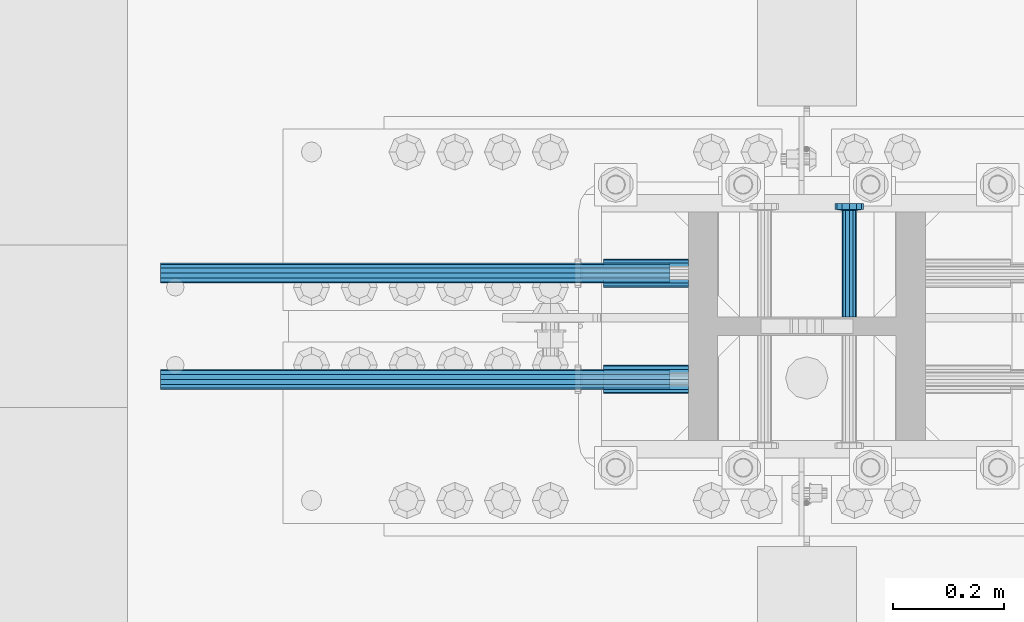
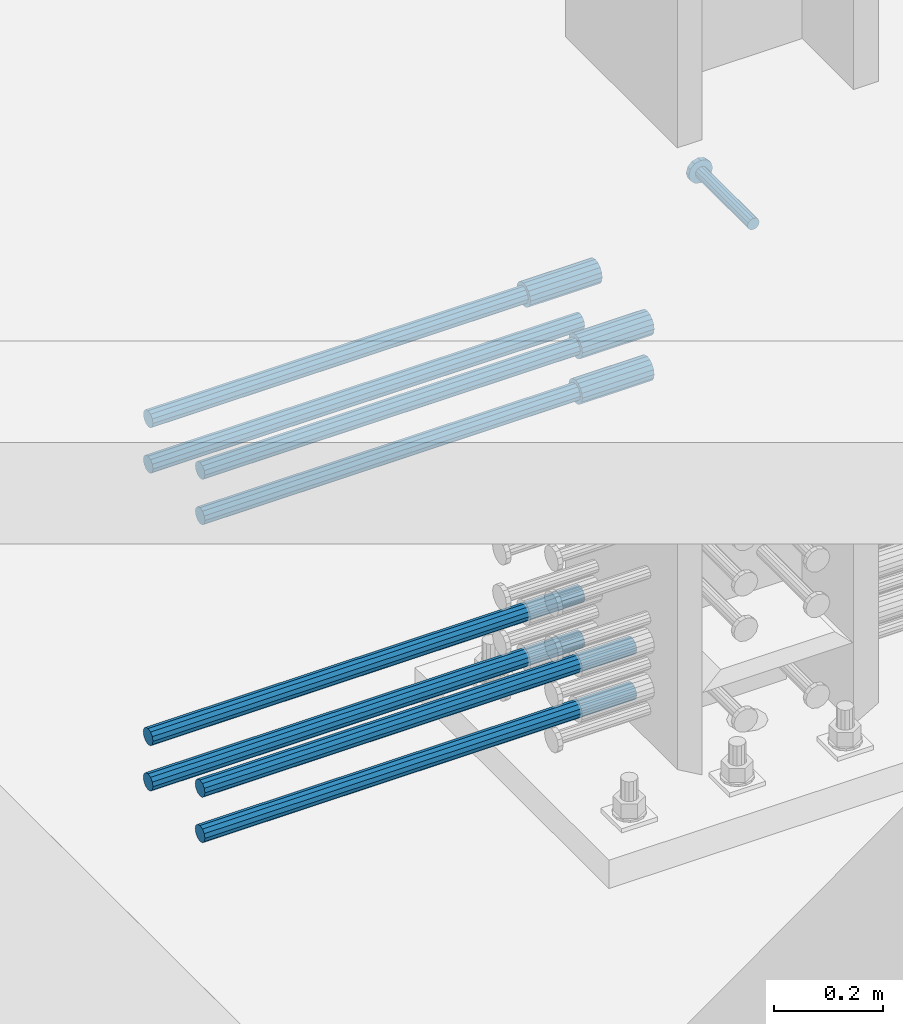
# One storey, part 1225 of 1763: 12 beams, 9 elements without a shape of their own.
"""IFC2X3 building model written with IfcOpenShell, lengths in millimetres."""

from ifc_helpers import new_model, si_unit, frame, origin_with_axes, place, context, subcontext, project, spatial, faceted_brep, material, type_object, element, aggregate, save


model = new_model("IFC2X3")

# Units and contexts
model_context = context("Model", 3, precision=1e-05, world=origin_with_axes())
body_context = subcontext(model_context, "Body", "Model", "MODEL_VIEW")
ifc_project = project(units=[si_unit("LENGTHUNIT", "METRE", prefix="MILLI"), si_unit("AREAUNIT", "SQUARE_METRE"), si_unit("VOLUMEUNIT", "CUBIC_METRE"), si_unit("MASSUNIT", "GRAM", prefix="KILO"), si_unit("TIMEUNIT", "SECOND"), si_unit("PLANEANGLEUNIT", "RADIAN"), si_unit("SOLIDANGLEUNIT", "STERADIAN"), si_unit("THERMODYNAMICTEMPERATUREUNIT", "DEGREE_CELSIUS"), si_unit("LUMINOUSINTENSITYUNIT", "LUMEN")], contexts=[model_context])

# Site, building, storey
site_placement = place(None, origin_with_axes())
site = spatial("IfcSite", under=ifc_project, at=site_placement, CompositionType="ELEMENT")
building_placement = place(site_placement, origin_with_axes())
building = spatial("IfcBuilding", under=site, at=building_placement, Name="Undefined", CompositionType="ELEMENT")
storey_placement = place(building_placement, origin_with_axes())
storey = spatial("IfcBuildingStorey", under=building, at=storey_placement, Name="Undefined", CompositionType="ELEMENT", Elevation=0.0)

# Assembly, beams
assembly_1_placement = place(storey_placement, origin_with_axes())
assembly_1 = element("IfcElementAssembly", 1, at=assembly_1_placement, inside=storey, Name="COLUMN", AssemblyPlace="NOTDEFINED", PredefinedType="RIGID_FRAME")
ifc_material_1 = material(Name="STEEL/A706-GR.80")
beam_type_1 = type_object("IfcBeamType", PredefinedType="NOTDEFINED")
beam_1_placement = place(assembly_1_placement, frame((-49615.1621920032, 361.950000000003, 4775.20000000009), z_axis=(0.0, 0.0, 1.0), x_axis=(-1.0, 0.0, 0.0)))
beam_1 = element("IfcBeam", 2, at=beam_1_placement, type_object=beam_type_1, material=ifc_material_1, Name="HALF COUPLER F", context=body_context, shape_type="Brep", body=[
    faceted_brep([(32.7659999999996, -8.95349999999962, -15.507916905568), (32.7659999999996, 0.0, -17.9070000000002), (32.7659999999996, 8.95349999999962, -15.507916905568), (32.7659999999996, 15.507916905568, -8.95350000000008), (32.7659999999996, 17.9069999999992, 0.0), (32.7659999999996, 15.507916905568, 8.95350000000008), (32.7659999999996, 8.95349999999962, 15.507916905568), (32.7659999999996, 0.0, 17.9070000000002), (32.7659999999996, -8.95349999999962, 15.507916905568), (32.7659999999996, -15.507916905568, 8.95350000000008), (32.7659999999996, -17.9069999999992, 0.0), (32.7659999999996, -15.507916905568, -8.95350000000008), (152.400103102711, -15.507916905568, 8.95350000000008), (152.400103102711, -8.95349999999962, 15.507916905568), (152.400103102711, -17.9069999999992, 0.0), (152.400103102711, -15.507916905568, -8.95350000000008), (152.400103102711, -8.95349999999962, -15.507916905568), (152.400103102711, 0.0, -17.9070000000002), (152.400103102711, 8.95349999999962, -15.507916905568), (152.400103102711, 15.507916905568, -8.95350000000008), (152.400103102711, 17.9069999999992, 0.0), (152.400103102711, 15.507916905568, 8.95350000000008), (152.400103102711, 8.95349999999962, 15.507916905568), (152.400103102711, 0.0, 17.9070000000002), (0.0, -23.466540125788, 9.72015918207308), (0.0, -17.9605122421381, 17.9605122421385), (0.0, -9.72015918207398, 23.4665401257867), (0.0, 0.0, 25.4000000000001), (0.0, 9.72015918207398, 23.4665401257867), (0.0, 17.9605122421381, 17.9605122421385), (0.0, 23.466540125788, 9.72015918207308), (0.0, 25.4000000000015, 0.0), (0.0, 23.466540125788, -9.72015918207308), (0.0, 17.9605122421381, -17.9605122421385), (0.0, 9.72015918207398, -23.4665401257867), (0.0, 0.0, -25.4000000000001), (0.0, -9.72015918207398, -23.4665401257867), (0.0, -17.9605122421381, -17.9605122421385), (0.0, -23.466540125788, -9.72015918207308), (0.0, -25.4000000000015, 0.0), (152.400103102711, -25.4000000000015, 0.0), (152.400103102711, -23.466540125788, 9.72015918207308), (152.400103102711, -17.9605122421381, 17.9605122421385), (152.400103102711, -9.72015918207398, 23.4665401257867), (152.400103102711, 0.0, 25.4000000000001), (152.400103102711, 9.72015918207398, 23.4665401257867), (152.400103102711, 17.9605122421381, 17.9605122421385), (152.400103102711, 23.466540125788, 9.72015918207308), (152.400103102711, 25.4000000000015, 0.0), (152.400103102711, 23.466540125788, -9.72015918207308), (152.400103102711, 17.9605122421381, -17.9605122421385), (152.400103102711, 9.72015918207398, -23.4665401257867), (152.400103102711, 0.0, -25.4000000000001), (152.400103102711, -9.72015918207398, -23.4665401257867), (152.400103102711, -17.9605122421381, -17.9605122421385), (152.400103102711, -23.466540125788, -9.72015918207308)], [[[0, 1, 2, 3, 4, 5, 6, 7, 8, 9, 10, 11]], [[12, 9, 8, 13]], [[14, 10, 9, 12]], [[15, 11, 10, 14]], [[16, 0, 11, 15]], [[17, 1, 0, 16]], [[18, 2, 1, 17]], [[19, 3, 2, 18]], [[20, 4, 3, 19]], [[21, 5, 4, 20]], [[22, 6, 5, 21]], [[23, 7, 6, 22]], [[13, 8, 7, 23]], [[24, 25, 26, 27, 28, 29, 30, 31, 32, 33, 34, 35, 36, 37, 38, 39]], [[24, 39, 40, 41]], [[25, 24, 41, 42]], [[26, 25, 42, 43]], [[27, 26, 43, 44]], [[28, 27, 44, 45]], [[29, 28, 45, 46]], [[30, 29, 46, 47]], [[31, 30, 47, 48]], [[32, 31, 48, 49]], [[33, 32, 49, 50]], [[34, 33, 50, 51]], [[35, 34, 51, 52]], [[36, 35, 52, 53]], [[37, 36, 53, 54]], [[38, 37, 54, 55]], [[39, 38, 55, 40]], [[54, 53, 52, 51, 50, 49, 48, 47, 46, 45, 44, 43, 42, 41, 40, 55], [21, 20, 19, 18, 17, 16, 15, 14, 12, 13, 23, 22]]]),
])
beam_2_placement = place(assembly_1_placement, frame((-49615.162260665, 552.449999999415, 4876.80000000009), z_axis=(0.0, 0.0, 1.0), x_axis=(-1.0, 0.0, 0.0)))
beam_2 = element("IfcBeam", 3, at=beam_2_placement, type_object=beam_type_1, material=ifc_material_1, Name="HALF COUPLER F", context=body_context, shape_type="Brep", body=[
    faceted_brep([(32.7659999999996, -8.95349999999962, -15.507916905568), (32.7659999999996, 0.0, -17.9070000000002), (32.7659999999996, 8.95349999999962, -15.507916905568), (32.7659999999996, 15.507916905568, -8.95350000000008), (32.7659999999996, 17.9069999999992, 0.0), (32.7659999999996, 15.507916905568, 8.95350000000008), (32.7659999999996, 8.95349999999962, 15.507916905568), (32.7659999999996, 0.0, 17.9070000000002), (32.7659999999996, -8.95349999999962, 15.507916905568), (32.7659999999996, -15.507916905568, 8.95350000000008), (32.7659999999996, -17.9069999999992, 0.0), (32.7659999999996, -15.507916905568, -8.95350000000008), (152.400103102711, -15.507916905568, 8.95350000000008), (152.400103102711, -8.95349999999962, 15.507916905568), (152.400103102711, -17.9069999999992, 0.0), (152.400103102711, -15.507916905568, -8.95350000000008), (152.400103102711, -8.95349999999962, -15.507916905568), (152.400103102711, 0.0, -17.9070000000002), (152.400103102711, 8.95349999999962, -15.507916905568), (152.400103102711, 15.507916905568, -8.95350000000008), (152.400103102711, 17.9069999999992, 0.0), (152.400103102711, 15.507916905568, 8.95350000000008), (152.400103102711, 8.95349999999962, 15.507916905568), (152.400103102711, 0.0, 17.9070000000002), (0.0, -23.466540125788, 9.72015918207308), (0.0, -17.9605122421381, 17.9605122421385), (0.0, -9.72015918207398, 23.4665401257867), (0.0, 0.0, 25.4000000000001), (0.0, 9.72015918207398, 23.4665401257867), (0.0, 17.9605122421381, 17.9605122421385), (0.0, 23.466540125788, 9.72015918207308), (0.0, 25.4000000000015, 0.0), (0.0, 23.466540125788, -9.72015918207308), (0.0, 17.9605122421381, -17.9605122421385), (0.0, 9.72015918207398, -23.4665401257867), (0.0, 0.0, -25.4000000000001), (0.0, -9.72015918207398, -23.4665401257867), (0.0, -17.9605122421381, -17.9605122421385), (0.0, -23.466540125788, -9.72015918207308), (0.0, -25.4000000000015, 0.0), (152.400103102711, -25.4000000000015, 0.0), (152.400103102711, -23.466540125788, 9.72015918207308), (152.400103102711, -17.9605122421381, 17.9605122421385), (152.400103102711, -9.72015918207398, 23.4665401257867), (152.400103102711, 0.0, 25.4000000000001), (152.400103102711, 9.72015918207398, 23.4665401257867), (152.400103102711, 17.9605122421381, 17.9605122421385), (152.400103102711, 23.466540125788, 9.72015918207308), (152.400103102711, 25.4000000000015, 0.0), (152.400103102711, 23.466540125788, -9.72015918207308), (152.400103102711, 17.9605122421381, -17.9605122421385), (152.400103102711, 9.72015918207398, -23.4665401257867), (152.400103102711, 0.0, -25.4000000000001), (152.400103102711, -9.72015918207398, -23.4665401257867), (152.400103102711, -17.9605122421381, -17.9605122421385), (152.400103102711, -23.466540125788, -9.72015918207308)], [[[0, 1, 2, 3, 4, 5, 6, 7, 8, 9, 10, 11]], [[12, 9, 8, 13]], [[14, 10, 9, 12]], [[15, 11, 10, 14]], [[16, 0, 11, 15]], [[17, 1, 0, 16]], [[18, 2, 1, 17]], [[19, 3, 2, 18]], [[20, 4, 3, 19]], [[21, 5, 4, 20]], [[22, 6, 5, 21]], [[23, 7, 6, 22]], [[13, 8, 7, 23]], [[24, 25, 26, 27, 28, 29, 30, 31, 32, 33, 34, 35, 36, 37, 38, 39]], [[24, 39, 40, 41]], [[25, 24, 41, 42]], [[26, 25, 42, 43]], [[27, 26, 43, 44]], [[28, 27, 44, 45]], [[29, 28, 45, 46]], [[30, 29, 46, 47]], [[31, 30, 47, 48]], [[32, 31, 48, 49]], [[33, 32, 49, 50]], [[34, 33, 50, 51]], [[35, 34, 51, 52]], [[36, 35, 52, 53]], [[37, 36, 53, 54]], [[38, 37, 54, 55]], [[39, 38, 55, 40]], [[54, 53, 52, 51, 50, 49, 48, 47, 46, 45, 44, 43, 42, 41, 40, 55], [21, 20, 19, 18, 17, 16, 15, 14, 12, 13, 23, 22]]]),
])
beam_3_placement = place(assembly_1_placement, frame((-49615.1621920032, 361.950000000003, 4876.80000000009), z_axis=(0.0, 0.0, 1.0), x_axis=(-1.0, 0.0, 0.0)))
beam_3 = element("IfcBeam", 4, at=beam_3_placement, type_object=beam_type_1, material=ifc_material_1, Name="HALF COUPLER F", context=body_context, shape_type="Brep", body=[
    faceted_brep([(32.7659999999996, -8.95349999999962, -15.507916905568), (32.7659999999996, 0.0, -17.9070000000002), (32.7659999999996, 8.95349999999962, -15.507916905568), (32.7659999999996, 15.507916905568, -8.95350000000008), (32.7659999999996, 17.9069999999992, 0.0), (32.7659999999996, 15.507916905568, 8.95350000000008), (32.7659999999996, 8.95349999999962, 15.507916905568), (32.7659999999996, 0.0, 17.9070000000002), (32.7659999999996, -8.95349999999962, 15.507916905568), (32.7659999999996, -15.507916905568, 8.95350000000008), (32.7659999999996, -17.9069999999992, 0.0), (32.7659999999996, -15.507916905568, -8.95350000000008), (152.400103102711, -15.507916905568, 8.95350000000008), (152.400103102711, -8.95349999999962, 15.507916905568), (152.400103102711, -17.9069999999992, 0.0), (152.400103102711, -15.507916905568, -8.95350000000008), (152.400103102711, -8.95349999999962, -15.507916905568), (152.400103102711, 0.0, -17.9070000000002), (152.400103102711, 8.95349999999962, -15.507916905568), (152.400103102711, 15.507916905568, -8.95350000000008), (152.400103102711, 17.9069999999992, 0.0), (152.400103102711, 15.507916905568, 8.95350000000008), (152.400103102711, 8.95349999999962, 15.507916905568), (152.400103102711, 0.0, 17.9070000000002), (0.0, -23.466540125788, 9.72015918207308), (0.0, -17.9605122421381, 17.9605122421385), (0.0, -9.72015918207398, 23.4665401257867), (0.0, 0.0, 25.4000000000001), (0.0, 9.72015918207398, 23.4665401257867), (0.0, 17.9605122421381, 17.9605122421385), (0.0, 23.466540125788, 9.72015918207308), (0.0, 25.4000000000015, 0.0), (0.0, 23.466540125788, -9.72015918207308), (0.0, 17.9605122421381, -17.9605122421385), (0.0, 9.72015918207398, -23.4665401257867), (0.0, 0.0, -25.4000000000001), (0.0, -9.72015918207398, -23.4665401257867), (0.0, -17.9605122421381, -17.9605122421385), (0.0, -23.466540125788, -9.72015918207308), (0.0, -25.4000000000015, 0.0), (152.400103102711, -25.4000000000015, 0.0), (152.400103102711, -23.466540125788, 9.72015918207308), (152.400103102711, -17.9605122421381, 17.9605122421385), (152.400103102711, -9.72015918207398, 23.4665401257867), (152.400103102711, 0.0, 25.4000000000001), (152.400103102711, 9.72015918207398, 23.4665401257867), (152.400103102711, 17.9605122421381, 17.9605122421385), (152.400103102711, 23.466540125788, 9.72015918207308), (152.400103102711, 25.4000000000015, 0.0), (152.400103102711, 23.466540125788, -9.72015918207308), (152.400103102711, 17.9605122421381, -17.9605122421385), (152.400103102711, 9.72015918207398, -23.4665401257867), (152.400103102711, 0.0, -25.4000000000001), (152.400103102711, -9.72015918207398, -23.4665401257867), (152.400103102711, -17.9605122421381, -17.9605122421385), (152.400103102711, -23.466540125788, -9.72015918207308)], [[[0, 1, 2, 3, 4, 5, 6, 7, 8, 9, 10, 11]], [[12, 9, 8, 13]], [[14, 10, 9, 12]], [[15, 11, 10, 14]], [[16, 0, 11, 15]], [[17, 1, 0, 16]], [[18, 2, 1, 17]], [[19, 3, 2, 18]], [[20, 4, 3, 19]], [[21, 5, 4, 20]], [[22, 6, 5, 21]], [[23, 7, 6, 22]], [[13, 8, 7, 23]], [[24, 25, 26, 27, 28, 29, 30, 31, 32, 33, 34, 35, 36, 37, 38, 39]], [[24, 39, 40, 41]], [[25, 24, 41, 42]], [[26, 25, 42, 43]], [[27, 26, 43, 44]], [[28, 27, 44, 45]], [[29, 28, 45, 46]], [[30, 29, 46, 47]], [[31, 30, 47, 48]], [[32, 31, 48, 49]], [[33, 32, 49, 50]], [[34, 33, 50, 51]], [[35, 34, 51, 52]], [[36, 35, 52, 53]], [[37, 36, 53, 54]], [[38, 37, 54, 55]], [[39, 38, 55, 40]], [[54, 53, 52, 51, 50, 49, 48, 47, 46, 45, 44, 43, 42, 41, 40, 55], [21, 20, 19, 18, 17, 16, 15, 14, 12, 13, 23, 22]]]),
])

# Assembly, beam
assembly_2_placement = place(storey_placement, origin_with_axes())
assembly_2 = element("IfcElementAssembly", 5, at=assembly_2_placement, inside=storey, Name="REBAR", AssemblyPlace="NOTDEFINED", PredefinedType="RIGID_FRAME")
beam_type_2 = type_object("IfcBeamType", Name="#11 REBAR", PredefinedType="NOTDEFINED")
beam_4_placement = place(assembly_2_placement, frame((-49647.9281232677, 361.949999997454, 4063.99999999999), z_axis=(0.0, 0.0, -1.0), x_axis=(-1.0, 0.0, 0.0)))
beam_4 = element("IfcBeam", 6, at=beam_4_placement, type_object=beam_type_2, material=ifc_material_1, Name="REBAR", ObjectType="#11 REBAR", context=body_context, shape_type="Brep", body=[
    faceted_brep([(0.0, -17.9069999999992, 0.0), (0.0, -15.507916905568, -8.95349999999962), (914.400000001086, -15.507916905568, -8.95349999999962), (914.400000001086, -17.9069999999992, 0.0), (0.0, -8.95349999999962, -15.507916905568), (914.400000001086, -8.95349999999962, -15.507916905568), (0.0, 0.0, -17.9070000000002), (914.400000001086, 0.0, -17.9070000000002), (0.0, 8.95349999999962, -15.507916905568), (914.400000001086, 8.95349999999962, -15.507916905568), (0.0, 15.507916905568, -8.95349999999962), (914.400000001086, 15.507916905568, -8.95349999999962), (0.0, 17.9069999999992, 0.0), (914.400000001086, 17.9069999999992, 0.0), (0.0, 15.507916905568, 8.95349999999962), (914.400000001086, 15.507916905568, 8.95349999999962), (0.0, 8.95349999999962, 15.507916905568), (914.400000001086, 8.95349999999962, 15.507916905568), (0.0, 0.0, 17.9070000000002), (914.400000001086, 0.0, 17.9070000000002), (0.0, -8.95349999999962, 15.507916905568), (914.400000001086, -8.95349999999962, 15.507916905568), (0.0, -15.507916905568, 8.95349999999962), (914.400000001086, -15.507916905568, 8.95349999999962)], [[[0, 1, 2, 3]], [[1, 4, 5, 2]], [[4, 6, 7, 5]], [[6, 8, 9, 7]], [[8, 10, 11, 9]], [[10, 12, 13, 11]], [[12, 14, 15, 13]], [[14, 16, 17, 15]], [[16, 18, 19, 17]], [[18, 20, 21, 19]], [[20, 22, 23, 21]], [[22, 0, 3, 23]], [[5, 7, 9, 11, 13, 15, 17, 19, 21, 23, 3, 2]], [[22, 20, 18, 16, 14, 12, 10, 8, 6, 4, 1, 0]]]),
])
aggregate(assembly_2, [beam_4])

assembly_3_placement = place(storey_placement, origin_with_axes())
assembly_3 = element("IfcElementAssembly", 7, at=assembly_3_placement, inside=storey, Name="REBAR", AssemblyPlace="NOTDEFINED", PredefinedType="RIGID_FRAME")
beam_5_placement = place(assembly_3_placement, frame((-49647.9281921188, 552.449999996867, 4063.99999999999), z_axis=(0.0, 0.0, -1.0), x_axis=(-1.0, 0.0, 0.0)))
beam_5 = element("IfcBeam", 8, at=beam_5_placement, type_object=beam_type_2, material=ifc_material_1, Name="REBAR", ObjectType="#11 REBAR", context=body_context, shape_type="Brep", body=[
    faceted_brep([(0.0, -17.9069999999992, 0.0), (0.0, -15.507916905568, -8.95349999999962), (914.400000001086, -15.507916905568, -8.95349999999962), (914.400000001086, -17.9069999999992, 0.0), (0.0, -8.95349999999962, -15.507916905568), (914.400000001086, -8.95349999999962, -15.507916905568), (0.0, 0.0, -17.9070000000002), (914.400000001086, 0.0, -17.9070000000002), (0.0, 8.95349999999962, -15.507916905568), (914.400000001086, 8.95349999999962, -15.507916905568), (0.0, 15.507916905568, -8.95349999999962), (914.400000001086, 15.507916905568, -8.95349999999962), (0.0, 17.9069999999992, 0.0), (914.400000001086, 17.9069999999992, 0.0), (0.0, 15.507916905568, 8.95349999999962), (914.400000001086, 15.507916905568, 8.95349999999962), (0.0, 8.95349999999962, 15.507916905568), (914.400000001086, 8.95349999999962, 15.507916905568), (0.0, 0.0, 17.9070000000002), (914.400000001086, 0.0, 17.9070000000002), (0.0, -8.95349999999962, 15.507916905568), (914.400000001086, -8.95349999999962, 15.507916905568), (0.0, -15.507916905568, 8.95349999999962), (914.400000001086, -15.507916905568, 8.95349999999962)], [[[0, 1, 2, 3]], [[1, 4, 5, 2]], [[4, 6, 7, 5]], [[6, 8, 9, 7]], [[8, 10, 11, 9]], [[10, 12, 13, 11]], [[12, 14, 15, 13]], [[14, 16, 17, 15]], [[16, 18, 19, 17]], [[18, 20, 21, 19]], [[20, 22, 23, 21]], [[22, 0, 3, 23]], [[5, 7, 9, 11, 13, 15, 17, 19, 21, 23, 3, 2]], [[22, 20, 18, 16, 14, 12, 10, 8, 6, 4, 1, 0]]]),
])
aggregate(assembly_3, [beam_5])

assembly_4_placement = place(storey_placement, origin_with_axes())
assembly_4 = element("IfcElementAssembly", 9, at=assembly_4_placement, inside=storey, Name="REBAR", AssemblyPlace="NOTDEFINED", PredefinedType="RIGID_FRAME")
beam_6_placement = place(assembly_4_placement, frame((-49647.9281232677, 361.949999997458, 4165.59999999999), z_axis=(0.0, 0.0, -1.0), x_axis=(-1.0, 0.0, 0.0)))
beam_6 = element("IfcBeam", 10, at=beam_6_placement, type_object=beam_type_2, material=ifc_material_1, Name="REBAR", ObjectType="#11 REBAR", context=body_context, shape_type="Brep", body=[
    faceted_brep([(0.0, -17.9069999999992, 0.0), (0.0, -15.507916905568, -8.95349999999962), (914.400000001086, -15.507916905568, -8.95349999999962), (914.400000001086, -17.9069999999992, 0.0), (0.0, -8.95349999999962, -15.507916905568), (914.400000001086, -8.95349999999962, -15.507916905568), (0.0, 0.0, -17.9070000000002), (914.400000001086, 0.0, -17.9070000000002), (0.0, 8.95349999999962, -15.507916905568), (914.400000001086, 8.95349999999962, -15.507916905568), (0.0, 15.507916905568, -8.95349999999962), (914.400000001086, 15.507916905568, -8.95349999999962), (0.0, 17.9069999999992, 0.0), (914.400000001086, 17.9069999999992, 0.0), (0.0, 15.507916905568, 8.95349999999962), (914.400000001086, 15.507916905568, 8.95349999999962), (0.0, 8.95349999999962, 15.507916905568), (914.400000001086, 8.95349999999962, 15.507916905568), (0.0, 0.0, 17.9070000000002), (914.400000001086, 0.0, 17.9070000000002), (0.0, -8.95349999999962, 15.507916905568), (914.400000001086, -8.95349999999962, 15.507916905568), (0.0, -15.507916905568, 8.95349999999962), (914.400000001086, -15.507916905568, 8.95349999999962)], [[[0, 1, 2, 3]], [[1, 4, 5, 2]], [[4, 6, 7, 5]], [[6, 8, 9, 7]], [[8, 10, 11, 9]], [[10, 12, 13, 11]], [[12, 14, 15, 13]], [[14, 16, 17, 15]], [[16, 18, 19, 17]], [[18, 20, 21, 19]], [[20, 22, 23, 21]], [[22, 0, 3, 23]], [[5, 7, 9, 11, 13, 15, 17, 19, 21, 23, 3, 2]], [[22, 20, 18, 16, 14, 12, 10, 8, 6, 4, 1, 0]]]),
])
aggregate(assembly_4, [beam_6])

assembly_5_placement = place(storey_placement, origin_with_axes())
assembly_5 = element("IfcElementAssembly", 11, at=assembly_5_placement, inside=storey, Name="REBAR", AssemblyPlace="NOTDEFINED", PredefinedType="RIGID_FRAME")
beam_7_placement = place(assembly_5_placement, frame((-49647.9281921188, 552.44999999687, 4165.59999999999), z_axis=(0.0, 0.0, -1.0), x_axis=(-1.0, 0.0, 0.0)))
beam_7 = element("IfcBeam", 12, at=beam_7_placement, type_object=beam_type_2, material=ifc_material_1, Name="REBAR", ObjectType="#11 REBAR", context=body_context, shape_type="Brep", body=[
    faceted_brep([(0.0, -17.9069999999992, 0.0), (0.0, -15.507916905568, -8.95349999999962), (914.400000001086, -15.507916905568, -8.95349999999962), (914.400000001086, -17.9069999999992, 0.0), (0.0, -8.95349999999962, -15.507916905568), (914.400000001086, -8.95349999999962, -15.507916905568), (0.0, 0.0, -17.9070000000002), (914.400000001086, 0.0, -17.9070000000002), (0.0, 8.95349999999962, -15.507916905568), (914.400000001086, 8.95349999999962, -15.507916905568), (0.0, 15.507916905568, -8.95349999999962), (914.400000001086, 15.507916905568, -8.95349999999962), (0.0, 17.9069999999992, 0.0), (914.400000001086, 17.9069999999992, 0.0), (0.0, 15.507916905568, 8.95349999999962), (914.400000001086, 15.507916905568, 8.95349999999962), (0.0, 8.95349999999962, 15.507916905568), (914.400000001086, 8.95349999999962, 15.507916905568), (0.0, 0.0, 17.9070000000002), (914.400000001086, 0.0, 17.9070000000002), (0.0, -8.95349999999962, 15.507916905568), (914.400000001086, -8.95349999999962, 15.507916905568), (0.0, -15.507916905568, 8.95349999999962), (914.400000001086, -15.507916905568, 8.95349999999962)], [[[0, 1, 2, 3]], [[1, 4, 5, 2]], [[4, 6, 7, 5]], [[6, 8, 9, 7]], [[8, 10, 11, 9]], [[10, 12, 13, 11]], [[12, 14, 15, 13]], [[14, 16, 17, 15]], [[16, 18, 19, 17]], [[18, 20, 21, 19]], [[20, 22, 23, 21]], [[22, 0, 3, 23]], [[5, 7, 9, 11, 13, 15, 17, 19, 21, 23, 3, 2]], [[22, 20, 18, 16, 14, 12, 10, 8, 6, 4, 1, 0]]]),
])
aggregate(assembly_5, [beam_7])

assembly_6_placement = place(storey_placement, origin_with_axes())
assembly_6 = element("IfcElementAssembly", 13, at=assembly_6_placement, inside=storey, Name="REBAR", AssemblyPlace="NOTDEFINED", PredefinedType="RIGID_FRAME")
beam_8_placement = place(assembly_6_placement, frame((-49647.9281920032, 361.949999998726, 4775.20000000006), z_axis=(0.0, 0.0, -1.0), x_axis=(-1.0, 0.0, 0.0)))
beam_8 = element("IfcBeam", 14, at=beam_8_placement, type_object=beam_type_2, material=ifc_material_1, Name="REBAR", ObjectType="#11 REBAR", context=body_context, shape_type="Brep", body=[
    faceted_brep([(0.0, -17.9069999999992, 0.0), (0.0, -15.507916905568, -8.95349999999962), (914.400000001086, -15.507916905568, -8.95349999999962), (914.400000001086, -17.9069999999992, 0.0), (0.0, -8.95349999999962, -15.507916905568), (914.400000001086, -8.95349999999962, -15.507916905568), (0.0, 0.0, -17.9070000000002), (914.400000001086, 0.0, -17.9070000000002), (0.0, 8.95349999999962, -15.507916905568), (914.400000001086, 8.95349999999962, -15.507916905568), (0.0, 15.507916905568, -8.95349999999962), (914.400000001086, 15.507916905568, -8.95349999999962), (0.0, 17.9069999999992, 0.0), (914.400000001086, 17.9069999999992, 0.0), (0.0, 15.507916905568, 8.95349999999962), (914.400000001086, 15.507916905568, 8.95349999999962), (0.0, 8.95349999999962, 15.507916905568), (914.400000001086, 8.95349999999962, 15.507916905568), (0.0, 0.0, 17.9070000000002), (914.400000001086, 0.0, 17.9070000000002), (0.0, -8.95349999999962, 15.507916905568), (914.400000001086, -8.95349999999962, 15.507916905568), (0.0, -15.507916905568, 8.95349999999962), (914.400000001086, -15.507916905568, 8.95349999999962)], [[[0, 1, 2, 3]], [[1, 4, 5, 2]], [[4, 6, 7, 5]], [[6, 8, 9, 7]], [[8, 10, 11, 9]], [[10, 12, 13, 11]], [[12, 14, 15, 13]], [[14, 16, 17, 15]], [[16, 18, 19, 17]], [[18, 20, 21, 19]], [[20, 22, 23, 21]], [[22, 0, 3, 23]], [[5, 7, 9, 11, 13, 15, 17, 19, 21, 23, 3, 2]], [[22, 20, 18, 16, 14, 12, 10, 8, 6, 4, 1, 0]]]),
])
aggregate(assembly_6, [beam_8])

assembly_7_placement = place(storey_placement, origin_with_axes())
assembly_7 = element("IfcElementAssembly", 15, at=assembly_7_placement, inside=storey, Name="REBAR", AssemblyPlace="NOTDEFINED", PredefinedType="RIGID_FRAME")
beam_9_placement = place(assembly_7_placement, frame((-49647.9282608549, 552.449999998142, 4775.20000000006), z_axis=(0.0, 0.0, -1.0), x_axis=(-1.0, 0.0, 0.0)))
beam_9 = element("IfcBeam", 16, at=beam_9_placement, type_object=beam_type_2, material=ifc_material_1, Name="REBAR", ObjectType="#11 REBAR", context=body_context, shape_type="Brep", body=[
    faceted_brep([(0.0, -17.9069999999992, 0.0), (0.0, -15.507916905568, -8.95349999999962), (914.400000001086, -15.507916905568, -8.95349999999962), (914.400000001086, -17.9069999999992, 0.0), (0.0, -8.95349999999962, -15.507916905568), (914.400000001086, -8.95349999999962, -15.507916905568), (0.0, 0.0, -17.9070000000002), (914.400000001086, 0.0, -17.9070000000002), (0.0, 8.95349999999962, -15.507916905568), (914.400000001086, 8.95349999999962, -15.507916905568), (0.0, 15.507916905568, -8.95349999999962), (914.400000001086, 15.507916905568, -8.95349999999962), (0.0, 17.9069999999992, 0.0), (914.400000001086, 17.9069999999992, 0.0), (0.0, 15.507916905568, 8.95349999999962), (914.400000001086, 15.507916905568, 8.95349999999962), (0.0, 8.95349999999962, 15.507916905568), (914.400000001086, 8.95349999999962, 15.507916905568), (0.0, 0.0, 17.9070000000002), (914.400000001086, 0.0, 17.9070000000002), (0.0, -8.95349999999962, 15.507916905568), (914.400000001086, -8.95349999999962, 15.507916905568), (0.0, -15.507916905568, 8.95349999999962), (914.400000001086, -15.507916905568, 8.95349999999962)], [[[0, 1, 2, 3]], [[1, 4, 5, 2]], [[4, 6, 7, 5]], [[6, 8, 9, 7]], [[8, 10, 11, 9]], [[10, 12, 13, 11]], [[12, 14, 15, 13]], [[14, 16, 17, 15]], [[16, 18, 19, 17]], [[18, 20, 21, 19]], [[20, 22, 23, 21]], [[22, 0, 3, 23]], [[5, 7, 9, 11, 13, 15, 17, 19, 21, 23, 3, 2]], [[22, 20, 18, 16, 14, 12, 10, 8, 6, 4, 1, 0]]]),
])
aggregate(assembly_7, [beam_9])

assembly_8_placement = place(storey_placement, origin_with_axes())
assembly_8 = element("IfcElementAssembly", 17, at=assembly_8_placement, inside=storey, Name="REBAR", AssemblyPlace="NOTDEFINED", PredefinedType="RIGID_FRAME")
beam_10_placement = place(assembly_8_placement, frame((-49647.9281920032, 361.949999998729, 4876.80000000006), z_axis=(0.0, 0.0, -1.0), x_axis=(-1.0, 0.0, 0.0)))
beam_10 = element("IfcBeam", 18, at=beam_10_placement, type_object=beam_type_2, material=ifc_material_1, Name="REBAR", ObjectType="#11 REBAR", context=body_context, shape_type="Brep", body=[
    faceted_brep([(0.0, -17.9069999999992, 0.0), (0.0, -15.507916905568, -8.95349999999962), (914.400000001086, -15.507916905568, -8.95349999999962), (914.400000001086, -17.9069999999992, 0.0), (0.0, -8.95349999999962, -15.507916905568), (914.400000001086, -8.95349999999962, -15.507916905568), (0.0, 0.0, -17.9070000000002), (914.400000001086, 0.0, -17.9070000000002), (0.0, 8.95349999999962, -15.507916905568), (914.400000001086, 8.95349999999962, -15.507916905568), (0.0, 15.507916905568, -8.95349999999962), (914.400000001086, 15.507916905568, -8.95349999999962), (0.0, 17.9069999999992, 0.0), (914.400000001086, 17.9069999999992, 0.0), (0.0, 15.507916905568, 8.95349999999962), (914.400000001086, 15.507916905568, 8.95349999999962), (0.0, 8.95349999999962, 15.507916905568), (914.400000001086, 8.95349999999962, 15.507916905568), (0.0, 0.0, 17.9070000000002), (914.400000001086, 0.0, 17.9070000000002), (0.0, -8.95349999999962, 15.507916905568), (914.400000001086, -8.95349999999962, 15.507916905568), (0.0, -15.507916905568, 8.95349999999962), (914.400000001086, -15.507916905568, 8.95349999999962)], [[[0, 1, 2, 3]], [[1, 4, 5, 2]], [[4, 6, 7, 5]], [[6, 8, 9, 7]], [[8, 10, 11, 9]], [[10, 12, 13, 11]], [[12, 14, 15, 13]], [[14, 16, 17, 15]], [[16, 18, 19, 17]], [[18, 20, 21, 19]], [[20, 22, 23, 21]], [[22, 0, 3, 23]], [[5, 7, 9, 11, 13, 15, 17, 19, 21, 23, 3, 2]], [[22, 20, 18, 16, 14, 12, 10, 8, 6, 4, 1, 0]]]),
])
aggregate(assembly_8, [beam_10])

assembly_9_placement = place(storey_placement, origin_with_axes())
assembly_9 = element("IfcElementAssembly", 19, at=assembly_9_placement, inside=storey, Name="REBAR", AssemblyPlace="NOTDEFINED", PredefinedType="RIGID_FRAME")
beam_11_placement = place(assembly_9_placement, frame((-49647.9282608549, 552.449999998145, 4876.80000000006), z_axis=(0.0, 0.0, -1.0), x_axis=(-1.0, 0.0, 0.0)))
beam_11 = element("IfcBeam", 20, at=beam_11_placement, type_object=beam_type_2, material=ifc_material_1, Name="REBAR", ObjectType="#11 REBAR", context=body_context, shape_type="Brep", body=[
    faceted_brep([(0.0, -17.9069999999992, 0.0), (0.0, -15.507916905568, -8.95349999999962), (914.400000001086, -15.507916905568, -8.95349999999962), (914.400000001086, -17.9069999999992, 0.0), (0.0, -8.95349999999962, -15.507916905568), (914.400000001086, -8.95349999999962, -15.507916905568), (0.0, 0.0, -17.9070000000002), (914.400000001086, 0.0, -17.9070000000002), (0.0, 8.95349999999962, -15.507916905568), (914.400000001086, 8.95349999999962, -15.507916905568), (0.0, 15.507916905568, -8.95349999999962), (914.400000001086, 15.507916905568, -8.95349999999962), (0.0, 17.9069999999992, 0.0), (914.400000001086, 17.9069999999992, 0.0), (0.0, 15.507916905568, 8.95349999999962), (914.400000001086, 15.507916905568, 8.95349999999962), (0.0, 8.95349999999962, 15.507916905568), (914.400000001086, 8.95349999999962, 15.507916905568), (0.0, 0.0, 17.9070000000002), (914.400000001086, 0.0, 17.9070000000002), (0.0, -8.95349999999962, 15.507916905568), (914.400000001086, -8.95349999999962, 15.507916905568), (0.0, -15.507916905568, 8.95349999999962), (914.400000001086, -15.507916905568, 8.95349999999962)], [[[0, 1, 2, 3]], [[1, 4, 5, 2]], [[4, 6, 7, 5]], [[6, 8, 9, 7]], [[8, 10, 11, 9]], [[10, 12, 13, 11]], [[12, 14, 15, 13]], [[14, 16, 17, 15]], [[16, 18, 19, 17]], [[18, 20, 21, 19]], [[20, 22, 23, 21]], [[22, 0, 3, 23]], [[5, 7, 9, 11, 13, 15, 17, 19, 21, 23, 3, 2]], [[22, 20, 18, 16, 14, 12, 10, 8, 6, 4, 1, 0]]]),
])
aggregate(assembly_9, [beam_11])

# Beam
ifc_material_2 = material(Name="STEEL/A108")
beam_type_3 = type_object("IfcBeamType", PredefinedType="NOTDEFINED")
beam_12_placement = place(assembly_1_placement, frame((-49326.2374118359, 473.869000000003, 4927.60000000008), z_axis=(1.0, 0.0, 0.0), x_axis=(0.0, 1.0, 0.0)))
beam_12 = element("IfcBeam", 21, at=beam_12_placement, type_object=beam_type_3, material=ifc_material_2, Name="HEADED STUD ANCHOR", context=body_context, shape_type="Brep", body=[
    faceted_brep([(0.0, -12.6999999999971, -1.81898940354586e-12), (3.63797880709171e-12, -11.0, -6.34999990463257), (191.00799999576, -11.0, -6.34999990454889), (191.007999995752, -12.6999998092651, 8.36735125631094e-11), (7.27595761418343e-12, -6.34999990463257, -11.0), (191.00799999576, -6.34999990463257, -10.9999999999163), (3.63797880709171e-12, 0.0, -12.6999998092651), (191.00799999576, 0.0, -12.6999998091815), (7.27595761418343e-12, 6.34999990463257, -11.0), (191.00799999576, 6.34999990463257, -10.9999999999163), (3.63797880709171e-12, 11.0, -6.34999990463257), (191.00799999576, 11.0, -6.34999990454889), (0.0, 12.6999999999971, -1.81898940354586e-12), (191.007999995752, 12.6999998092651, 8.36735125631094e-11), (0.0, 11.0, 6.34999990463257), (191.007999995752, 11.0, 6.34999990471624), (-3.63797880709171e-12, 6.34999990463257, 11.0), (191.007999995749, 6.34999990463257, 11.0000000000837), (-3.63797880709171e-12, 0.0, 12.6999998092651), (191.007999995749, 0.0, 12.6999998093488), (-3.63797880709171e-12, -6.34999990463257, 11.0), (191.007999995749, -6.34999990463257, 11.0000000000837), (0.0, -11.0, 6.34999990463257), (191.007999995752, -11.0, 6.34999990471624), (193.039999995715, -22.0, -12.6999998091796), (193.039999995708, -25.3999996185303, 8.54925019666553e-11), (193.039999995719, -12.6999998092651, -21.9999999999145), (193.039999995719, 0.0, -25.3999996184448), (193.039999995719, 12.6999998092651, -21.9999999999145), (193.039999995715, 22.0, -12.6999998091796), (193.039999995708, 25.3999996185303, 8.54925019666553e-11), (193.039999995704, 22.0, 12.6999998093506), (193.039999995701, 12.6999998092651, 22.0000000000855), (193.039999995697, 0.0, 25.3999996186158), (193.039999995701, -12.6999998092651, 22.0000000000855), (193.039999995704, -22.0, 12.6999998093506), (203.199999995486, -22.0, -12.6999998091742), (203.199999995482, -25.3999996185303, 9.09494701772928e-11), (203.199999995493, -12.6999998092651, -21.9999999999091), (203.199999995493, 0.0, -25.3999996184393), (203.199999995493, 12.6999998092651, -21.9999999999091), (203.199999995486, 22.0, -12.6999998091742), (203.199999995482, 25.3999996185303, 9.09494701772928e-11), (203.199999995479, 22.0, 12.6999998093561), (203.199999995475, 12.6999998092651, 22.0000000000909), (203.199999995471, 0.0, 25.3999996186212), (203.199999995475, -12.6999998092651, 22.0000000000909), (203.199999995479, -22.0, 12.6999998093561)], [[[0, 1, 2, 3]], [[1, 4, 5, 2]], [[4, 6, 7, 5]], [[6, 8, 9, 7]], [[8, 10, 11, 9]], [[10, 12, 13, 11]], [[12, 14, 15, 13]], [[14, 16, 17, 15]], [[16, 18, 19, 17]], [[18, 20, 21, 19]], [[20, 22, 23, 21]], [[22, 0, 3, 23]], [[22, 20, 18, 16, 14, 12, 10, 8, 6, 4, 1, 0]], [[3, 2, 24, 25]], [[2, 5, 26, 24]], [[5, 7, 27, 26]], [[7, 9, 28, 27]], [[9, 11, 29, 28]], [[11, 13, 30, 29]], [[13, 15, 31, 30]], [[15, 17, 32, 31]], [[17, 19, 33, 32]], [[19, 21, 34, 33]], [[21, 23, 35, 34]], [[23, 3, 25, 35]], [[25, 24, 36, 37]], [[24, 26, 38, 36]], [[26, 27, 39, 38]], [[27, 28, 40, 39]], [[28, 29, 41, 40]], [[29, 30, 42, 41]], [[30, 31, 43, 42]], [[31, 32, 44, 43]], [[32, 33, 45, 44]], [[33, 34, 46, 45]], [[34, 35, 47, 46]], [[35, 25, 37, 47]], [[38, 39, 40, 41, 42, 43, 44, 45, 46, 47, 37, 36]]]),
])

aggregate(assembly_1, [beam_1, beam_2, beam_3, beam_12])

save(model, "model.ifc")
